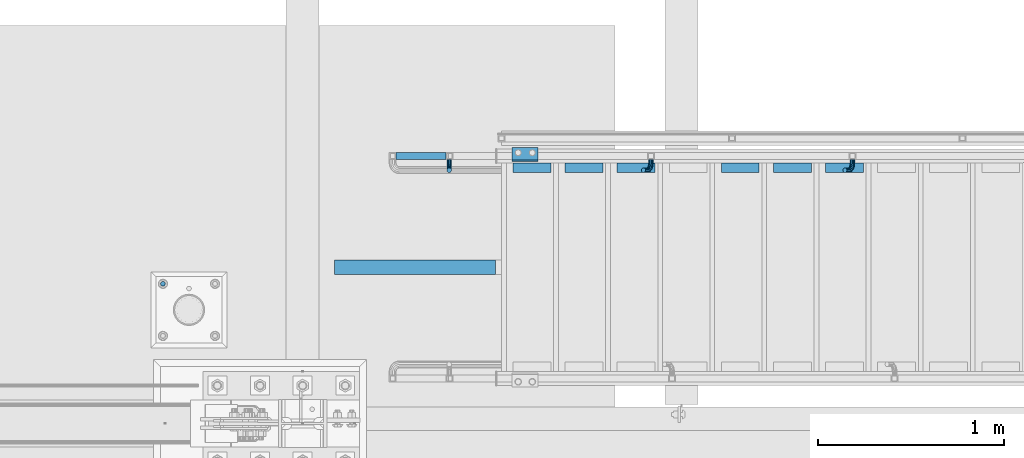
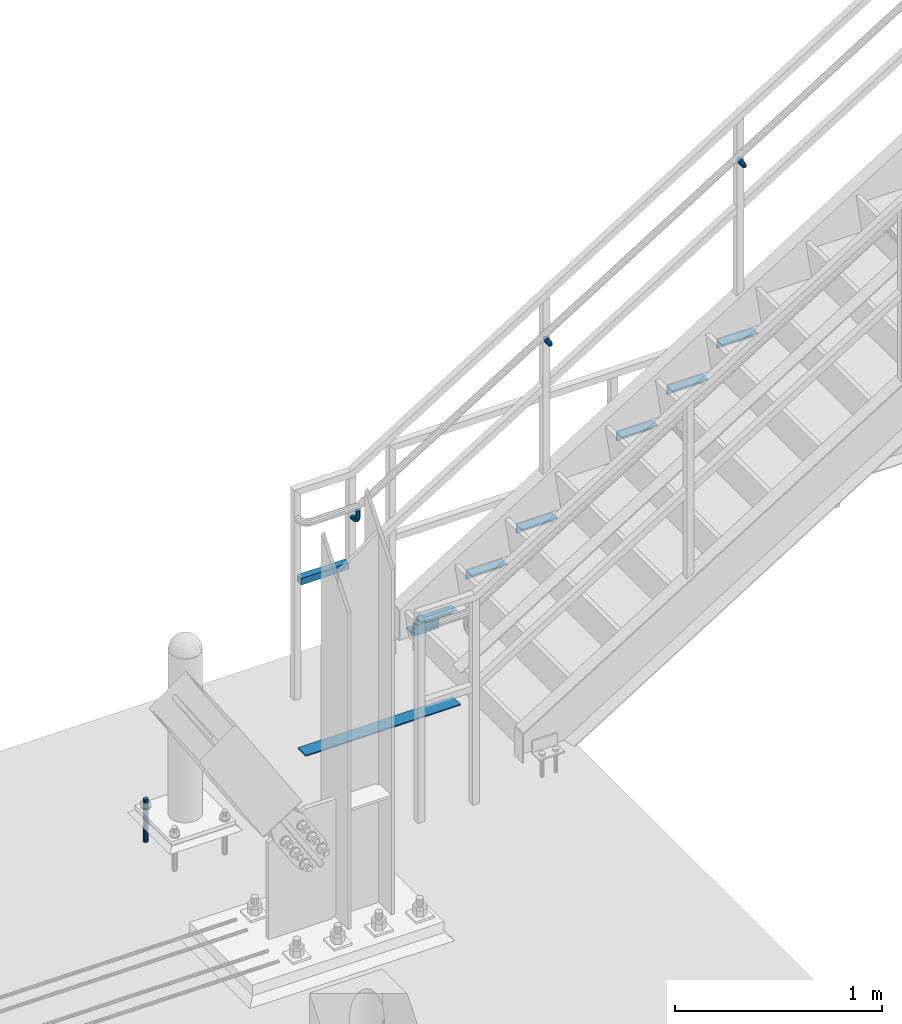
# One storey, part 2411 of 3843: 12 beams, 1 member, 4 elements without a shape of their own.
"""IFC2X3 building model written with IfcOpenShell, lengths in millimetres."""

from ifc_helpers import new_model, si_unit, frame, origin_with_axes, place, context, subcontext, project, spatial, faceted_brep, material, type_object, element, aggregate, save


model = new_model("IFC2X3")

# Units and contexts
model_context = context("Model", 3, precision=1e-05, world=origin_with_axes())
body_context = subcontext(model_context, "Body", "Model", "MODEL_VIEW")
ifc_project = project(units=[si_unit("LENGTHUNIT", "METRE", prefix="MILLI"), si_unit("AREAUNIT", "SQUARE_METRE"), si_unit("VOLUMEUNIT", "CUBIC_METRE"), si_unit("MASSUNIT", "GRAM", prefix="KILO"), si_unit("TIMEUNIT", "SECOND"), si_unit("PLANEANGLEUNIT", "RADIAN"), si_unit("SOLIDANGLEUNIT", "STERADIAN"), si_unit("THERMODYNAMICTEMPERATUREUNIT", "DEGREE_CELSIUS"), si_unit("LUMINOUSINTENSITYUNIT", "LUMEN")], contexts=[model_context])

# Site, building, storey
site_placement = place(None, origin_with_axes())
site = spatial("IfcSite", under=ifc_project, at=site_placement, CompositionType="ELEMENT")
building_placement = place(site_placement, origin_with_axes())
building = spatial("IfcBuilding", under=site, at=building_placement, Name="Undefined", CompositionType="ELEMENT")
storey_placement = place(building_placement, origin_with_axes())
storey = spatial("IfcBuildingStorey", under=building, at=storey_placement, Name="Undefined", CompositionType="ELEMENT", Elevation=0.0)

# Assembly, beam
assembly_1_placement = place(storey_placement, origin_with_axes())
assembly_1 = element("IfcElementAssembly", 1, at=assembly_1_placement, inside=storey, Name="STAIR", AssemblyPlace="NOTDEFINED", PredefinedType="RIGID_FRAME")
ifc_material_1 = material(Name="STEEL/A572-50")
beam_type_1 = type_object("IfcBeamType", Name="L3X3X3/8", PredefinedType="NOTDEFINED")
beam_1_placement = place(assembly_1_placement, frame((31603.95, 90558.9375000096, 30518.1), z_axis=(0.0, 1.0, 0.0), x_axis=(1.0, 0.0, 0.0)))
beam_1 = element("IfcBeam", 2, at=beam_1_placement, type_object=beam_type_1, material=ifc_material_1, Name="CLEAT", ObjectType="L3X3X3/8", context=body_context, shape_type="Brep", body=[
    faceted_brep([(0.0, 38.0999999999985, -38.0999999999985), (0.0, 38.0999999999985, 38.0999999999985), (139.699999999997, 38.0999999999985, 38.0999999999985), (139.699999999997, 38.0999999999985, -38.0999999999985), (0.0, 28.5750000000007, 38.0999999999985), (139.699999999997, 28.5750000000007, 38.0999999999985), (0.0, 28.5750000000007, -28.5750000000007), (139.699999999997, 28.5750000000007, -28.5750000000007), (0.0, -38.0999999999985, -28.5750000000007), (139.699999999997, -38.0999999999985, -28.5750000000007), (0.0, -38.0999999999985, -38.0999999999985), (139.699999999997, -38.0999999999985, -38.0999999999985)], [[[0, 1, 2, 3]], [[1, 4, 5, 2]], [[4, 6, 7, 5]], [[6, 8, 9, 7]], [[8, 10, 11, 9]], [[10, 0, 3, 11]], [[5, 7, 9, 11, 3, 2]], [[10, 8, 6, 4, 1, 0]]]),
])

assembly_2_placement = place(storey_placement, origin_with_axes())
assembly_2 = element("IfcElementAssembly", 3, at=assembly_2_placement, inside=storey, Name="TEMPLATE", AssemblyPlace="NOTDEFINED", PredefinedType="RIGID_FRAME")
ifc_material_2 = material(Name="STEEL/316 SS")
beam_type_2 = type_object("IfcBeamType", PredefinedType="NOTDEFINED")
beam_2_placement = place(assembly_2_placement, frame((29730.7, 89865.2, 30581.6), z_axis=(-1.0, 0.0, 0.0), x_axis=(0.0, 0.0, -1.0)))
beam_2 = element("IfcBeam", 4, at=beam_2_placement, type_object=beam_type_2, material=ifc_material_2, Name="ANCHOR_ROD", context=body_context, shape_type="Brep", body=[
    faceted_brep([(0.0, -12.6999999999971, 0.0), (0.0, -10.9985226280696, -6.34999999999854), (253.999, -10.9985226280696, -6.34999999999854), (253.999, -12.6999999999971, 0.0), (0.0, -6.35000000000582, -10.9985226280623), (253.999, -6.35000000000582, -10.9985226280623), (0.0, 0.0, -12.6999999999971), (253.999, 0.0, -12.6999999999971), (0.0, 6.35000000000582, -10.9985226280623), (253.999, 6.35000000000582, -10.9985226280623), (0.0, 10.9985226280696, -6.34999999999854), (253.999, 10.9985226280696, -6.34999999999854), (0.0, 12.6999999999971, 0.0), (253.999, 12.6999999999971, 0.0), (0.0, 10.9985226280696, 6.34999999999854), (253.999, 10.9985226280696, 6.34999999999854), (0.0, 6.35000000000582, 10.9985226280623), (253.999, 6.35000000000582, 10.9985226280623), (0.0, 0.0, 12.6999999999971), (253.999, 0.0, 12.6999999999971), (0.0, -6.35000000000582, 10.9985226280623), (253.999, -6.35000000000582, 10.9985226280623), (0.0, -10.9985226280696, 6.34999999999854), (253.999, -10.9985226280696, 6.34999999999854)], [[[0, 1, 2, 3]], [[1, 4, 5, 2]], [[4, 6, 7, 5]], [[6, 8, 9, 7]], [[8, 10, 11, 9]], [[10, 12, 13, 11]], [[12, 14, 15, 13]], [[14, 16, 17, 15]], [[16, 18, 19, 17]], [[18, 20, 21, 19]], [[20, 22, 23, 21]], [[22, 0, 3, 23]], [[5, 7, 9, 11, 13, 15, 17, 19, 21, 23, 3, 2]], [[22, 20, 18, 16, 14, 12, 10, 8, 6, 4, 1, 0]]]),
])
aggregate(assembly_2, [beam_2])

assembly_3_placement = place(storey_placement, origin_with_axes())
assembly_3 = element("IfcElementAssembly", 5, at=assembly_3_placement, inside=storey, Name="RAIL", AssemblyPlace="NOTDEFINED", PredefinedType="RIGID_FRAME")
ifc_material_3 = material()
beam_type_3 = type_object("IfcBeamType", Name="HSS1-1/2X1-1/2X1/4", PredefinedType="NOTDEFINED")
beam_3_placement = place(assembly_3_placement, frame((30962.6000000001, 90551.0000000455, 31013.4), z_axis=(0.0, 0.0, 1.0), x_axis=(1.0, 0.0, 0.0)))
beam_3 = element("IfcBeam", 6, at=beam_3_placement, type_object=beam_type_3, material=ifc_material_3, Name="RAIL", ObjectType="HSS1-1/2X1-1/2X1/4", context=body_context, shape_type="Brep", body=[
    faceted_brep([(285.750000765285, -19.0499992350015, 19.0499992350015), (285.750000765285, -19.0499992350015, -19.0499992350015), (285.750000765285, 19.0499992350015, -19.0499992350015), (285.750000765285, 19.0499992350015, 19.0499992350015), (285.750000765009, -12.6999993300014, 12.6999993299978), (285.750000765009, 12.6999993300014, 12.6999993299978), (285.750000765009, 12.6999993300014, -12.6999993299978), (285.750000765009, -12.6999993300014, -12.6999993299978), (19.0499992350015, 19.0499992350015, -19.0499992350015), (19.0499992350015, 19.0499992350015, 19.0499992350015), (19.0499992350015, -19.0499992350015, 19.0499992350015), (19.0499992350015, -19.0499992350015, -19.0499992350015), (19.0499992350015, 12.6999993299978, 12.6999993299978), (19.0499992350015, -12.6999993299978, 12.6999993299978), (19.0499992350015, -12.6999993299978, -12.6999993299978), (19.0499992350015, 12.6999993299978, -12.6999993299978)], [[[0, 1, 2, 3], [4, 5, 6, 7]], [[8, 9, 3, 2]], [[9, 10, 0, 3]], [[10, 11, 1, 0]], [[11, 8, 2, 1]], [[11, 10, 9, 8], [12, 13, 14, 15]], [[14, 13, 4, 7]], [[15, 14, 7, 6]], [[12, 15, 6, 5]], [[13, 12, 5, 4]]]),
])

# Beam
ifc_material_4 = material(Name="STEEL/A36")
beam_type_4 = type_object("IfcBeamType", Name="L2X2X3/16", PredefinedType="NOTDEFINED")
beam_4_placement = place(assembly_1_placement, frame((33284.6169176732, 90487.4999999996, 31619.8250000043), z_axis=(0.0, -1.0, 0.0), x_axis=(1.0, 0.0, 0.0)))
beam_4 = element("IfcBeam", 7, at=beam_4_placement, type_object=beam_type_4, material=ifc_material_4, Name="ANGLE", ObjectType="L2X2X3/16", context=body_context, shape_type="Brep", body=[
    faceted_brep([(0.0, 25.4000000000015, -25.4000000000015), (0.0, 25.4000000000015, 25.4000000000015), (203.199999999997, 25.4000000000015, 25.4000000000015), (203.199999999997, 25.4000000000015, -25.4000000000015), (0.0, 20.6375000000007, 25.4000000000015), (203.199999999997, 20.6375000000007, 25.4000000000015), (0.0, 20.6375000000007, -20.6375000000007), (203.199999999997, 20.6375000000007, -20.6375000000007), (0.0, -25.4000000000015, -20.6375000000007), (203.199999999997, -25.4000000000015, -20.6375000000007), (0.0, -25.4000000000015, -25.4000000000015), (203.199999999997, -25.4000000000015, -25.4000000000015)], [[[0, 1, 2, 3]], [[1, 4, 5, 2]], [[4, 6, 7, 5]], [[6, 8, 9, 7]], [[8, 10, 11, 9]], [[10, 0, 3, 11]], [[5, 7, 9, 11, 3, 2]], [[10, 8, 6, 4, 1, 0]]]),
])

beam_5_placement = place(assembly_1_placement, frame((33005.2169176732, 90487.4999999996, 31445.6535714329), z_axis=(0.0, -1.0, 0.0), x_axis=(1.0, 0.0, 0.0)))
beam_5 = element("IfcBeam", 8, at=beam_5_placement, type_object=beam_type_4, material=ifc_material_4, Name="ANGLE", ObjectType="L2X2X3/16", context=body_context, shape_type="Brep", body=[
    faceted_brep([(0.0, 25.4000000000015, -25.4000000000015), (0.0, 25.4000000000015, 25.4000000000015), (203.199999999997, 25.4000000000015, 25.4000000000015), (203.199999999997, 25.4000000000015, -25.4000000000015), (0.0, 20.6375000000007, 25.4000000000015), (203.199999999997, 20.6375000000007, 25.4000000000015), (0.0, 20.6375000000007, -20.6375000000007), (203.199999999997, 20.6375000000007, -20.6375000000007), (0.0, -25.4000000000015, -20.6375000000007), (203.199999999997, -25.4000000000015, -20.6375000000007), (0.0, -25.4000000000015, -25.4000000000015), (203.199999999997, -25.4000000000015, -25.4000000000015)], [[[0, 1, 2, 3]], [[1, 4, 5, 2]], [[4, 6, 7, 5]], [[6, 8, 9, 7]], [[8, 10, 11, 9]], [[10, 0, 3, 11]], [[5, 7, 9, 11, 3, 2]], [[10, 8, 6, 4, 1, 0]]]),
])

beam_6_placement = place(assembly_1_placement, frame((32725.8169176732, 90487.4999999996, 31271.4821428615), z_axis=(0.0, -1.0, 0.0), x_axis=(1.0, 0.0, 0.0)))
beam_6 = element("IfcBeam", 9, at=beam_6_placement, type_object=beam_type_4, material=ifc_material_4, Name="ANGLE", ObjectType="L2X2X3/16", context=body_context, shape_type="Brep", body=[
    faceted_brep([(0.0, 25.4000000000015, -25.4000000000015), (0.0, 25.4000000000015, 25.4000000000015), (203.199999999997, 25.4000000000015, 25.4000000000015), (203.199999999997, 25.4000000000015, -25.4000000000015), (0.0, 20.6375000000007, 25.4000000000015), (203.199999999997, 20.6375000000007, 25.4000000000015), (0.0, 20.6375000000007, -20.6375000000007), (203.199999999997, 20.6375000000007, -20.6375000000007), (0.0, -25.4000000000015, -20.6375000000007), (203.199999999997, -25.4000000000015, -20.6375000000007), (0.0, -25.4000000000015, -25.4000000000015), (203.199999999997, -25.4000000000015, -25.4000000000015)], [[[0, 1, 2, 3]], [[1, 4, 5, 2]], [[4, 6, 7, 5]], [[6, 8, 9, 7]], [[8, 10, 11, 9]], [[10, 0, 3, 11]], [[5, 7, 9, 11, 3, 2]], [[10, 8, 6, 4, 1, 0]]]),
])

beam_7_placement = place(assembly_1_placement, frame((32167.0169176732, 90487.4999999996, 30923.1392857186), z_axis=(0.0, -1.0, 0.0), x_axis=(1.0, 0.0, 0.0)))
beam_7 = element("IfcBeam", 10, at=beam_7_placement, type_object=beam_type_4, material=ifc_material_4, Name="ANGLE", ObjectType="L2X2X3/16", context=body_context, shape_type="Brep", body=[
    faceted_brep([(0.0, 25.4000000000015, -25.4000000000015), (0.0, 25.4000000000015, 25.4000000000015), (203.199999999997, 25.4000000000015, 25.4000000000015), (203.199999999997, 25.4000000000015, -25.4000000000015), (0.0, 20.6375000000007, 25.4000000000015), (203.199999999997, 20.6375000000007, 25.4000000000015), (0.0, 20.6375000000007, -20.6375000000007), (203.199999999997, 20.6375000000007, -20.6375000000007), (0.0, -25.4000000000015, -20.6375000000007), (203.199999999997, -25.4000000000015, -20.6375000000007), (0.0, -25.4000000000015, -25.4000000000015), (203.199999999997, -25.4000000000015, -25.4000000000015)], [[[0, 1, 2, 3]], [[1, 4, 5, 2]], [[4, 6, 7, 5]], [[6, 8, 9, 7]], [[8, 10, 11, 9]], [[10, 0, 3, 11]], [[5, 7, 9, 11, 3, 2]], [[10, 8, 6, 4, 1, 0]]]),
])

beam_8_placement = place(assembly_1_placement, frame((31887.6169176732, 90487.4999999996, 30748.9678571472), z_axis=(0.0, -1.0, 0.0), x_axis=(1.0, 0.0, 0.0)))
beam_8 = element("IfcBeam", 11, at=beam_8_placement, type_object=beam_type_4, material=ifc_material_4, Name="ANGLE", ObjectType="L2X2X3/16", context=body_context, shape_type="Brep", body=[
    faceted_brep([(0.0, 25.4000000000015, -25.4000000000015), (0.0, 25.4000000000015, 25.4000000000015), (203.199999999997, 25.4000000000015, 25.4000000000015), (203.199999999997, 25.4000000000015, -25.4000000000015), (0.0, 20.6375000000007, 25.4000000000015), (203.199999999997, 20.6375000000007, 25.4000000000015), (0.0, 20.6375000000007, -20.6375000000007), (203.199999999997, 20.6375000000007, -20.6375000000007), (0.0, -25.4000000000015, -20.6375000000007), (203.199999999997, -25.4000000000015, -20.6375000000007), (0.0, -25.4000000000015, -25.4000000000015), (203.199999999997, -25.4000000000015, -25.4000000000015)], [[[0, 1, 2, 3]], [[1, 4, 5, 2]], [[4, 6, 7, 5]], [[6, 8, 9, 7]], [[8, 10, 11, 9]], [[10, 0, 3, 11]], [[5, 7, 9, 11, 3, 2]], [[10, 8, 6, 4, 1, 0]]]),
])

beam_9_placement = place(assembly_1_placement, frame((31608.2169176732, 90487.4999999996, 30574.7964285758), z_axis=(0.0, -1.0, 0.0), x_axis=(1.0, 0.0, 0.0)))
beam_9 = element("IfcBeam", 12, at=beam_9_placement, type_object=beam_type_4, material=ifc_material_4, Name="ANGLE", ObjectType="L2X2X3/16", context=body_context, shape_type="Brep", body=[
    faceted_brep([(0.0, 25.4000000000015, -25.4000000000015), (0.0, 25.4000000000015, 25.4000000000015), (203.199999999997, 25.4000000000015, 25.4000000000015), (203.199999999997, 25.4000000000015, -25.4000000000015), (0.0, 20.6375000000007, 25.4000000000015), (203.199999999997, 20.6375000000007, 25.4000000000015), (0.0, 20.6375000000007, -20.6375000000007), (203.199999999997, 20.6375000000007, -20.6375000000007), (0.0, -25.4000000000015, -20.6375000000007), (203.199999999997, -25.4000000000015, -20.6375000000007), (0.0, -25.4000000000015, -25.4000000000015), (203.199999999997, -25.4000000000015, -25.4000000000015)], [[[0, 1, 2, 3]], [[1, 4, 5, 2]], [[4, 6, 7, 5]], [[6, 8, 9, 7]], [[8, 10, 11, 9]], [[10, 0, 3, 11]], [[5, 7, 9, 11, 3, 2]], [[10, 8, 6, 4, 1, 0]]]),
])

aggregate(assembly_1, [beam_1, beam_4, beam_5, beam_6, beam_7, beam_8, beam_9])

beam_type_5 = type_object("IfcBeamType", PredefinedType="NOTDEFINED")
beam_10_placement = place(assembly_3_placement, frame((33428.8179704286, 90531.9500000455, 32629.5359728499), z_axis=(-0.848616882600527, 0.0, -0.529007926750974), x_axis=(0.0, -1.0, 0.0)))
beam_10 = element("IfcBeam", 13, at=beam_10_placement, type_object=beam_type_5, material=ifc_material_4, Name="BRACKET ARM", context=body_context, shape_type="Brep", body=[
    faceted_brep([(0.0, -12.6999999999971, 0.0), (0.0, -10.9985226280696, -6.34999999999854), (19.0500015258731, -10.9985226280623, -6.34999999999854), (19.0500015258731, -12.6999999999971, -6.33008312433958e-10), (0.0, -6.35000000000582, -10.9985226280623), (19.0500015258731, -6.34999999999854, -10.9985226280623), (0.0, 0.0, -12.6999999999971), (19.0500015258731, 0.0, -12.6999999999971), (0.0, 6.35000000000582, -10.9985226280623), (19.0500015258731, 6.34999999999854, -10.9985226280623), (0.0, 10.9985226280696, -6.34999999999854), (19.0500015258731, 10.9985226280623, -6.34999999999854), (0.0, 12.6999999999971, 0.0), (19.0500015258731, 12.6999999999971, 0.0), (0.0, 10.9985226280696, 6.34999999999854), (19.0500015258731, 10.9985226280623, 6.34999999999854), (0.0, 6.35000000000582, 10.9985226280623), (19.0500015258731, 6.34999999999854, 10.9985226280623), (0.0, 0.0, 12.6999999999971), (19.0500015258731, 0.0, 12.6999999999971), (0.0, -6.35000000000582, 10.9985226280623), (19.0500015258731, -6.34999999999854, 10.9985226280623), (0.0, -10.9985226280696, 6.34999999999854), (19.0500015258731, -10.9985226280623, 6.34999999999854), (38.4903193060891, -8.8330803677236, -3.34694050252438e-10), (37.8391921052389, -7.26112024908798, 6.34999999974389), (36.0602795104642, -2.96644533684594, 10.9985226280041), (33.6302397149266, 2.90018969451194, 12.7000000002226), (31.2001999194181, 8.76682472604443, 10.9985226285644), (29.4212873247307, 13.061499638774, 6.35000000070431), (28.7701601240115, 14.6334597580644, 7.78527464717627e-10), (29.4212873248762, 13.0614996394288, -6.34999999929278), (31.2001999196509, 8.76682472718676, -10.9985226275603), (33.6302397151885, 2.90018969582889, -12.6999999997788), (36.0602795106824, -2.96644533571089, -10.9985226281206), (37.8391921053699, -7.26112024843314, -6.35000000026048), (53.7678987435793, 3.38210125690239, -6.3499999994383), (54.9710249311902, 2.17897506880399, 5.0931703299284e-10), (50.4808968708676, 6.66910312997061, -10.9985226273784), (45.9907688103704, 11.1592311906061, -12.6999999991458), (41.5006407498004, 15.6493592510378, -10.9985226270364), (38.213638876914, 18.9363611235749, -6.34999999884167), (37.0105126890558, 20.1394873109457, 1.20053300634027e-09), (38.2136388766667, 18.9363611228473, 6.35000000115542), (41.5006407493784, 15.6493592497718, 10.9985226290883), (45.9907688098756, 11.1592311891436, 12.7000000008557), (50.4808968704456, 6.66910312870459, 10.9985226287463), (53.7678987433319, 3.38210125617479, 6.35000000055879), (64.4111202489148, 19.3108078951118, -6.34999999821594), (65.9830803677178, 18.6596806939051, 1.77533365786076e-09), (60.1164453365491, 21.0897204901557, -10.9985226262725), (54.2498103051475, 23.5197602857806, -12.6999999981927), (48.3831752736587, 25.9498000811873, -10.9985226262434), (44.0885003610601, 27.7287126756128, -6.34999999817228), (42.516540241937, 28.3798398759754, 1.83354131877422e-09), (44.08850036074, 27.7287126747688, 6.35000000183209), (48.3831752731057, 25.9498000797321, 10.9985226298813), (54.2498103045073, 23.5197602840999, 12.7000000018088), (60.1164453359961, 21.0897204886933, 10.9985226298522), (64.4111202485947, 19.3108078942678, 6.35000000178115), (68.1485226282239, 38.0999984746086, -6.3499999967753), (69.8499999999913, 38.0999984741211, 2.92493496090174e-09), (63.500000000291, 38.0999984749651, -10.9985226249628), (57.1500000003434, 38.0999984750961, -12.6999999970722), (50.8000000002939, 38.0999984749651, -10.998522625312), (46.1514773720992, 38.0999984746086, -6.34999999737192), (44.4499999999971, 38.0999984741211, 2.58296495303512e-09), (46.1514773717645, 38.0999984736336, 6.35000000262517), (50.7999999996973, 38.0999984732771, 10.9985226308127), (57.1499999996449, 38.0999984731461, 12.700000002922), (63.4999999996944, 38.0999984732771, 10.9985226311619), (68.1485226278892, 38.0999984736336, 6.35000000322179), (68.1485226280638, 76.2000000002372, -6.34999999414867), (69.8499999999913, 76.199999999757, 5.84986992180347e-09), (63.5, 76.200000000601, -10.9985226222125), (57.1499999999942, 76.2000000007247, -12.6999999941472), (50.7999999999884, 76.200000000601, -10.9985226222125), (46.1514773719246, 76.2000000002372, -6.34999999414867), (44.4499999999971, 76.199999999757, 5.84986992180347e-09), (46.1514773719246, 76.1999999992695, 6.35000000584841), (50.7999999999884, 76.1999999989057, 10.9985226339122), (57.1499999999942, 76.199999998782, 12.700000005847), (63.5, 76.1999999989057, 10.9985226339122), (68.1485226280638, 76.1999999992695, 6.35000000584841)], [[[0, 1, 2, 3]], [[1, 4, 5, 2]], [[4, 6, 7, 5]], [[6, 8, 9, 7]], [[8, 10, 11, 9]], [[10, 12, 13, 11]], [[12, 14, 15, 13]], [[14, 16, 17, 15]], [[16, 18, 19, 17]], [[18, 20, 21, 19]], [[20, 22, 23, 21]], [[22, 0, 3, 23]], [[22, 20, 18, 16, 14, 12, 10, 8, 6, 4, 1, 0]], [[23, 3, 24, 25]], [[21, 23, 25, 26]], [[19, 21, 26, 27]], [[17, 19, 27, 28]], [[15, 17, 28, 29]], [[13, 15, 29, 30]], [[11, 13, 30, 31]], [[9, 11, 31, 32]], [[7, 9, 32, 33]], [[5, 7, 33, 34]], [[2, 5, 34, 35]], [[3, 2, 35, 24]], [[35, 36, 37, 24]], [[34, 38, 36, 35]], [[33, 39, 38, 34]], [[32, 40, 39, 33]], [[31, 41, 40, 32]], [[30, 42, 41, 31]], [[29, 43, 42, 30]], [[28, 44, 43, 29]], [[27, 45, 44, 28]], [[26, 46, 45, 27]], [[25, 47, 46, 26]], [[24, 37, 47, 25]], [[36, 48, 49, 37]], [[38, 50, 48, 36]], [[39, 51, 50, 38]], [[40, 52, 51, 39]], [[41, 53, 52, 40]], [[42, 54, 53, 41]], [[43, 55, 54, 42]], [[44, 56, 55, 43]], [[45, 57, 56, 44]], [[46, 58, 57, 45]], [[47, 59, 58, 46]], [[37, 49, 59, 47]], [[48, 60, 61, 49]], [[50, 62, 60, 48]], [[51, 63, 62, 50]], [[52, 64, 63, 51]], [[53, 65, 64, 52]], [[54, 66, 65, 53]], [[55, 67, 66, 54]], [[56, 68, 67, 55]], [[57, 69, 68, 56]], [[58, 70, 69, 57]], [[59, 71, 70, 58]], [[49, 61, 71, 59]], [[61, 60, 72, 73]], [[60, 62, 74, 72]], [[62, 63, 75, 74]], [[63, 64, 76, 75]], [[64, 65, 77, 76]], [[65, 66, 78, 77]], [[66, 67, 79, 78]], [[67, 68, 80, 79]], [[68, 69, 81, 80]], [[69, 70, 82, 81]], [[70, 71, 83, 82]], [[71, 61, 73, 83]], [[74, 75, 76, 77, 78, 79, 80, 81, 82, 83, 73, 72]]]),
])

beam_11_placement = place(assembly_3_placement, frame((32348.3801709882, 90531.9500000455, 31956.0163056327), z_axis=(-0.848616882600527, 0.0, -0.529007926750974), x_axis=(0.0, -1.0, 0.0)))
beam_11 = element("IfcBeam", 14, at=beam_11_placement, type_object=beam_type_5, material=ifc_material_4, Name="BRACKET ARM", context=body_context, shape_type="Brep", body=[
    faceted_brep([(0.0, -12.6999999999971, 0.0), (0.0, -10.9985226280696, -6.34999999999854), (19.0500015258731, -10.9985226280623, -6.34999999999854), (19.0500015258731, -12.6999999999971, -6.33008312433958e-10), (0.0, -6.35000000000582, -10.9985226280623), (19.0500015258731, -6.34999999999854, -10.9985226280623), (0.0, 0.0, -12.6999999999971), (19.0500015258731, 0.0, -12.6999999999971), (0.0, 6.35000000000582, -10.9985226280623), (19.0500015258731, 6.34999999999854, -10.9985226280623), (0.0, 10.9985226280696, -6.34999999999854), (19.0500015258731, 10.9985226280623, -6.34999999999854), (0.0, 12.6999999999971, 0.0), (19.0500015258731, 12.6999999999971, 0.0), (0.0, 10.9985226280696, 6.34999999999854), (19.0500015258731, 10.9985226280623, 6.34999999999854), (0.0, 6.35000000000582, 10.9985226280623), (19.0500015258731, 6.34999999999854, 10.9985226280623), (0.0, 0.0, 12.6999999999971), (19.0500015258731, 0.0, 12.6999999999971), (0.0, -6.35000000000582, 10.9985226280623), (19.0500015258731, -6.34999999999854, 10.9985226280623), (0.0, -10.9985226280696, 6.34999999999854), (19.0500015258731, -10.9985226280623, 6.34999999999854), (38.4903193060891, -8.8330803677236, -3.34694050252438e-10), (37.8391921052389, -7.26112024908798, 6.34999999974389), (36.0602795104642, -2.96644533684594, 10.9985226280041), (33.6302397149266, 2.90018969451194, 12.7000000002226), (31.2001999194181, 8.76682472604443, 10.9985226285644), (29.4212873247307, 13.061499638774, 6.35000000070431), (28.7701601240115, 14.6334597580644, 7.78527464717627e-10), (29.4212873248762, 13.0614996394288, -6.34999999929278), (31.2001999196509, 8.76682472718676, -10.9985226275603), (33.6302397151885, 2.90018969582889, -12.6999999997788), (36.0602795106824, -2.96644533571089, -10.9985226281206), (37.8391921053699, -7.26112024843314, -6.35000000026048), (53.7678987435793, 3.38210125690239, -6.3499999994383), (54.9710249311902, 2.17897506880399, 5.0931703299284e-10), (50.4808968708676, 6.66910312997061, -10.9985226273784), (45.9907688103704, 11.1592311906061, -12.6999999991458), (41.5006407498004, 15.6493592510378, -10.9985226270364), (38.213638876914, 18.9363611235749, -6.34999999884167), (37.0105126890558, 20.1394873109457, 1.20053300634027e-09), (38.2136388766667, 18.9363611228473, 6.35000000115542), (41.5006407493784, 15.6493592497718, 10.9985226290883), (45.9907688098756, 11.1592311891436, 12.7000000008557), (50.4808968704456, 6.66910312870459, 10.9985226287463), (53.7678987433319, 3.38210125617479, 6.35000000055879), (64.4111202489148, 19.3108078951118, -6.34999999821594), (65.9830803677178, 18.6596806939051, 1.77533365786076e-09), (60.1164453365491, 21.0897204901557, -10.9985226262725), (54.2498103051475, 23.5197602857806, -12.6999999981927), (48.3831752736587, 25.9498000811873, -10.9985226262434), (44.0885003610601, 27.7287126756128, -6.34999999817228), (42.516540241937, 28.3798398759754, 1.83354131877422e-09), (44.08850036074, 27.7287126747688, 6.35000000183209), (48.3831752731057, 25.9498000797321, 10.9985226298813), (54.2498103045073, 23.5197602840999, 12.7000000018088), (60.1164453359961, 21.0897204886933, 10.9985226298522), (64.4111202485947, 19.3108078942678, 6.35000000178115), (68.1485226282239, 38.0999984746086, -6.3499999967753), (69.8499999999913, 38.0999984741211, 2.92493496090174e-09), (63.500000000291, 38.0999984749651, -10.9985226249628), (57.1500000003434, 38.0999984750961, -12.6999999970722), (50.8000000002939, 38.0999984749651, -10.998522625312), (46.1514773720992, 38.0999984746086, -6.34999999737192), (44.4499999999971, 38.0999984741211, 2.58296495303512e-09), (46.1514773717645, 38.0999984736336, 6.35000000262517), (50.7999999996973, 38.0999984732771, 10.9985226308127), (57.1499999996449, 38.0999984731461, 12.700000002922), (63.4999999996944, 38.0999984732771, 10.9985226311619), (68.1485226278892, 38.0999984736336, 6.35000000322179), (68.1485226280638, 76.2000000002372, -6.34999999414867), (69.8499999999913, 76.199999999757, 5.84986992180347e-09), (63.5, 76.200000000601, -10.9985226222125), (57.1499999999942, 76.2000000007247, -12.6999999941472), (50.7999999999884, 76.200000000601, -10.9985226222125), (46.1514773719246, 76.2000000002372, -6.34999999414867), (44.4499999999971, 76.199999999757, 5.84986992180347e-09), (46.1514773719246, 76.1999999992695, 6.35000000584841), (50.7999999999884, 76.1999999989057, 10.9985226339122), (57.1499999999942, 76.199999998782, 12.700000005847), (63.5, 76.1999999989057, 10.9985226339122), (68.1485226280638, 76.1999999992695, 6.35000000584841)], [[[0, 1, 2, 3]], [[1, 4, 5, 2]], [[4, 6, 7, 5]], [[6, 8, 9, 7]], [[8, 10, 11, 9]], [[10, 12, 13, 11]], [[12, 14, 15, 13]], [[14, 16, 17, 15]], [[16, 18, 19, 17]], [[18, 20, 21, 19]], [[20, 22, 23, 21]], [[22, 0, 3, 23]], [[22, 20, 18, 16, 14, 12, 10, 8, 6, 4, 1, 0]], [[23, 3, 24, 25]], [[21, 23, 25, 26]], [[19, 21, 26, 27]], [[17, 19, 27, 28]], [[15, 17, 28, 29]], [[13, 15, 29, 30]], [[11, 13, 30, 31]], [[9, 11, 31, 32]], [[7, 9, 32, 33]], [[5, 7, 33, 34]], [[2, 5, 34, 35]], [[3, 2, 35, 24]], [[35, 36, 37, 24]], [[34, 38, 36, 35]], [[33, 39, 38, 34]], [[32, 40, 39, 33]], [[31, 41, 40, 32]], [[30, 42, 41, 31]], [[29, 43, 42, 30]], [[28, 44, 43, 29]], [[27, 45, 44, 28]], [[26, 46, 45, 27]], [[25, 47, 46, 26]], [[24, 37, 47, 25]], [[36, 48, 49, 37]], [[38, 50, 48, 36]], [[39, 51, 50, 38]], [[40, 52, 51, 39]], [[41, 53, 52, 40]], [[42, 54, 53, 41]], [[43, 55, 54, 42]], [[44, 56, 55, 43]], [[45, 57, 56, 44]], [[46, 58, 57, 45]], [[47, 59, 58, 46]], [[37, 49, 59, 47]], [[48, 60, 61, 49]], [[50, 62, 60, 48]], [[51, 63, 62, 50]], [[52, 64, 63, 51]], [[53, 65, 64, 52]], [[54, 66, 65, 53]], [[55, 67, 66, 54]], [[56, 68, 67, 55]], [[57, 69, 68, 56]], [[58, 70, 69, 57]], [[59, 71, 70, 58]], [[49, 61, 71, 59]], [[61, 60, 72, 73]], [[60, 62, 74, 72]], [[62, 63, 75, 74]], [[63, 64, 76, 75]], [[64, 65, 77, 76]], [[65, 66, 78, 77]], [[66, 67, 79, 78]], [[67, 68, 80, 79]], [[68, 69, 81, 80]], [[69, 70, 82, 81]], [[70, 71, 83, 82]], [[71, 61, 73, 83]], [[74, 75, 76, 77, 78, 79, 80, 81, 82, 83, 73, 72]]]),
])

beam_12_placement = place(assembly_3_placement, frame((31265.8125005141, 90531.9500000455, 31299.1499998101), z_axis=(-1.0, 0.0, 0.0), x_axis=(0.0, -1.0, 0.0)))
beam_12 = element("IfcBeam", 15, at=beam_12_placement, type_object=beam_type_5, material=ifc_material_4, Name="BRACKET ARM", context=body_context, shape_type="Brep", body=[
    faceted_brep([(0.0, -12.6999999999971, 0.0), (0.0, -10.9985226280696, -6.34999999999854), (19.0500015258731, -10.9985226280623, -6.34999999999854), (19.0500015258731, -12.6999999999971, -6.33008312433958e-10), (0.0, -6.35000000000582, -10.9985226280623), (19.0500015258731, -6.34999999999854, -10.9985226280623), (0.0, 0.0, -12.6999999999971), (19.0500015258731, 0.0, -12.6999999999971), (0.0, 6.35000000000582, -10.9985226280623), (19.0500015258731, 6.34999999999854, -10.9985226280623), (0.0, 10.9985226280696, -6.34999999999854), (19.0500015258731, 10.9985226280623, -6.34999999999854), (0.0, 12.6999999999971, 0.0), (19.0500015258731, 12.6999999999971, 0.0), (0.0, 10.9985226280696, 6.34999999999854), (19.0500015258731, 10.9985226280623, 6.34999999999854), (0.0, 6.35000000000582, 10.9985226280623), (19.0500015258731, 6.34999999999854, 10.9985226280623), (0.0, 0.0, 12.6999999999971), (19.0500015258731, 0.0, 12.6999999999971), (0.0, -6.35000000000582, 10.9985226280623), (19.0500015258731, -6.34999999999854, 10.9985226280623), (0.0, -10.9985226280696, 6.34999999999854), (19.0500015258731, -10.9985226280623, 6.34999999999854), (38.4903193060891, -8.8330803677236, -3.34694050252438e-10), (37.8391921052389, -7.26112024908798, 6.34999999974389), (36.0602795104642, -2.96644533684594, 10.9985226280041), (33.6302397149266, 2.90018969451194, 12.7000000002226), (31.2001999194181, 8.76682472604443, 10.9985226285644), (29.4212873247307, 13.061499638774, 6.35000000070431), (28.7701601240115, 14.6334597580644, 7.78527464717627e-10), (29.4212873248762, 13.0614996394288, -6.34999999929278), (31.2001999196509, 8.76682472718676, -10.9985226275603), (33.6302397151885, 2.90018969582889, -12.6999999997788), (36.0602795106824, -2.96644533571089, -10.9985226281206), (37.8391921053699, -7.26112024843314, -6.35000000026048), (53.7678987435793, 3.38210125690239, -6.3499999994383), (54.9710249311902, 2.17897506880399, 5.0931703299284e-10), (50.4808968708676, 6.66910312997061, -10.9985226273784), (45.9907688103704, 11.1592311906061, -12.6999999991458), (41.5006407498004, 15.6493592510378, -10.9985226270364), (38.213638876914, 18.9363611235749, -6.34999999884167), (37.0105126890558, 20.1394873109457, 1.20053300634027e-09), (38.2136388766667, 18.9363611228473, 6.35000000115542), (41.5006407493784, 15.6493592497718, 10.9985226290883), (45.9907688098756, 11.1592311891436, 12.7000000008557), (50.4808968704456, 6.66910312870459, 10.9985226287463), (53.7678987433319, 3.38210125617479, 6.35000000055879), (64.4111202489148, 19.3108078951118, -6.34999999821594), (65.9830803677178, 18.6596806939051, 1.77533365786076e-09), (60.1164453365491, 21.0897204901557, -10.9985226262725), (54.2498103051475, 23.5197602857806, -12.6999999981927), (48.3831752736587, 25.9498000811873, -10.9985226262434), (44.0885003610601, 27.7287126756128, -6.34999999817228), (42.516540241937, 28.3798398759754, 1.83354131877422e-09), (44.08850036074, 27.7287126747688, 6.35000000183209), (48.3831752731057, 25.9498000797321, 10.9985226298813), (54.2498103045073, 23.5197602840999, 12.7000000018088), (60.1164453359961, 21.0897204886933, 10.9985226298522), (64.4111202485947, 19.3108078942678, 6.35000000178115), (68.1485226282239, 38.0999984746086, -6.3499999967753), (69.8499999999913, 38.0999984741211, 2.92493496090174e-09), (63.500000000291, 38.0999984749651, -10.9985226249628), (57.1500000003434, 38.0999984750961, -12.6999999970722), (50.8000000002939, 38.0999984749651, -10.998522625312), (46.1514773720992, 38.0999984746086, -6.34999999737192), (44.4499999999971, 38.0999984741211, 2.58296495303512e-09), (46.1514773717645, 38.0999984736336, 6.35000000262517), (50.7999999996973, 38.0999984732771, 10.9985226308127), (57.1499999996449, 38.0999984731461, 12.700000002922), (63.4999999996944, 38.0999984732771, 10.9985226311619), (68.1485226278892, 38.0999984736336, 6.35000000322179), (68.1485226280638, 76.2000000002372, -6.34999999414867), (69.8499999999913, 76.199999999757, 5.84986992180347e-09), (63.5, 76.200000000601, -10.9985226222125), (57.1499999999942, 76.2000000007247, -12.6999999941472), (50.7999999999884, 76.200000000601, -10.9985226222125), (46.1514773719246, 76.2000000002372, -6.34999999414867), (44.4499999999971, 76.199999999757, 5.84986992180347e-09), (46.1514773719246, 76.1999999992695, 6.35000000584841), (50.7999999999884, 76.1999999989057, 10.9985226339122), (57.1499999999942, 76.199999998782, 12.700000005847), (63.5, 76.1999999989057, 10.9985226339122), (68.1485226280638, 76.1999999992695, 6.35000000584841)], [[[0, 1, 2, 3]], [[1, 4, 5, 2]], [[4, 6, 7, 5]], [[6, 8, 9, 7]], [[8, 10, 11, 9]], [[10, 12, 13, 11]], [[12, 14, 15, 13]], [[14, 16, 17, 15]], [[16, 18, 19, 17]], [[18, 20, 21, 19]], [[20, 22, 23, 21]], [[22, 0, 3, 23]], [[22, 20, 18, 16, 14, 12, 10, 8, 6, 4, 1, 0]], [[23, 3, 24, 25]], [[21, 23, 25, 26]], [[19, 21, 26, 27]], [[17, 19, 27, 28]], [[15, 17, 28, 29]], [[13, 15, 29, 30]], [[11, 13, 30, 31]], [[9, 11, 31, 32]], [[7, 9, 32, 33]], [[5, 7, 33, 34]], [[2, 5, 34, 35]], [[3, 2, 35, 24]], [[35, 36, 37, 24]], [[34, 38, 36, 35]], [[33, 39, 38, 34]], [[32, 40, 39, 33]], [[31, 41, 40, 32]], [[30, 42, 41, 31]], [[29, 43, 42, 30]], [[28, 44, 43, 29]], [[27, 45, 44, 28]], [[26, 46, 45, 27]], [[25, 47, 46, 26]], [[24, 37, 47, 25]], [[36, 48, 49, 37]], [[38, 50, 48, 36]], [[39, 51, 50, 38]], [[40, 52, 51, 39]], [[41, 53, 52, 40]], [[42, 54, 53, 41]], [[43, 55, 54, 42]], [[44, 56, 55, 43]], [[45, 57, 56, 44]], [[46, 58, 57, 45]], [[47, 59, 58, 46]], [[37, 49, 59, 47]], [[48, 60, 61, 49]], [[50, 62, 60, 48]], [[51, 63, 62, 50]], [[52, 64, 63, 51]], [[53, 65, 64, 52]], [[54, 66, 65, 53]], [[55, 67, 66, 54]], [[56, 68, 67, 55]], [[57, 69, 68, 56]], [[58, 70, 69, 57]], [[59, 71, 70, 58]], [[49, 61, 71, 59]], [[61, 60, 72, 73]], [[60, 62, 74, 72]], [[62, 63, 75, 74]], [[63, 64, 76, 75]], [[64, 65, 77, 76]], [[65, 66, 78, 77]], [[66, 67, 79, 78]], [[67, 68, 80, 79]], [[68, 69, 81, 80]], [[69, 70, 82, 81]], [[70, 71, 83, 82]], [[71, 61, 73, 83]], [[74, 75, 76, 77, 78, 79, 80, 81, 82, 83, 73, 72]]]),
])

aggregate(assembly_3, [beam_10, beam_11, beam_12, beam_3])

# Assembly, member
assembly_4_placement = place(storey_placement, origin_with_axes())
assembly_4 = element("IfcElementAssembly", 16, at=assembly_4_placement, inside=storey, Name="ref.", AssemblyPlace="NOTDEFINED", PredefinedType="RIGID_FRAME")
ifc_material_5 = material(Name="STEEL/Steel_Undefined")
member_type = type_object("IfcMemberType", PredefinedType="NOTDEFINED")
member_placement = place(assembly_4_placement, frame((31515.05, 89954.1000000455, 30476.825), z_axis=(0.0, -1.0, 0.0), x_axis=(-1.0, 0.0, 0.0)))
member = element("IfcMember", 17, at=member_placement, type_object=member_type, material=ifc_material_5, Name="ref.", context=body_context, shape_type="Brep", body=[
    faceted_brep([(0.0, 3.17500000000291, -38.0999999999985), (0.0, 3.17500000000291, 38.0999999999985), (863.599999999999, 3.17499999999927, 38.1000000000058), (863.599999999999, 3.17499999999927, -38.1000000000058), (0.0, -3.17500000000291, 38.0999999999985), (863.599999999999, -3.17499999999927, 38.1000000000058), (0.0, -3.17500000000291, -38.0999999999985), (863.599999999999, -3.17499999999927, -38.1000000000058)], [[[0, 1, 2, 3]], [[1, 4, 5, 2]], [[4, 6, 7, 5]], [[6, 0, 3, 7]], [[5, 7, 3, 2]], [[6, 4, 1, 0]]]),
])
aggregate(assembly_4, [member])

save(model, "model.ifc")
